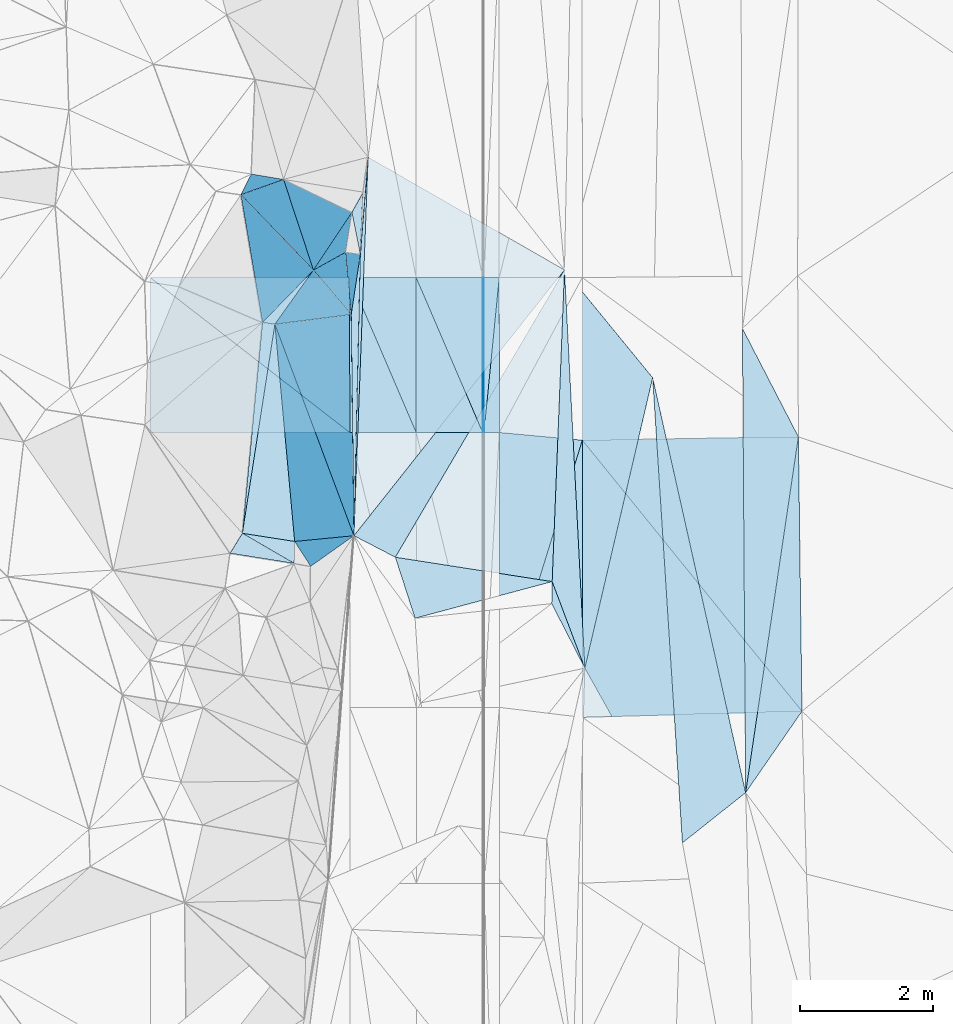
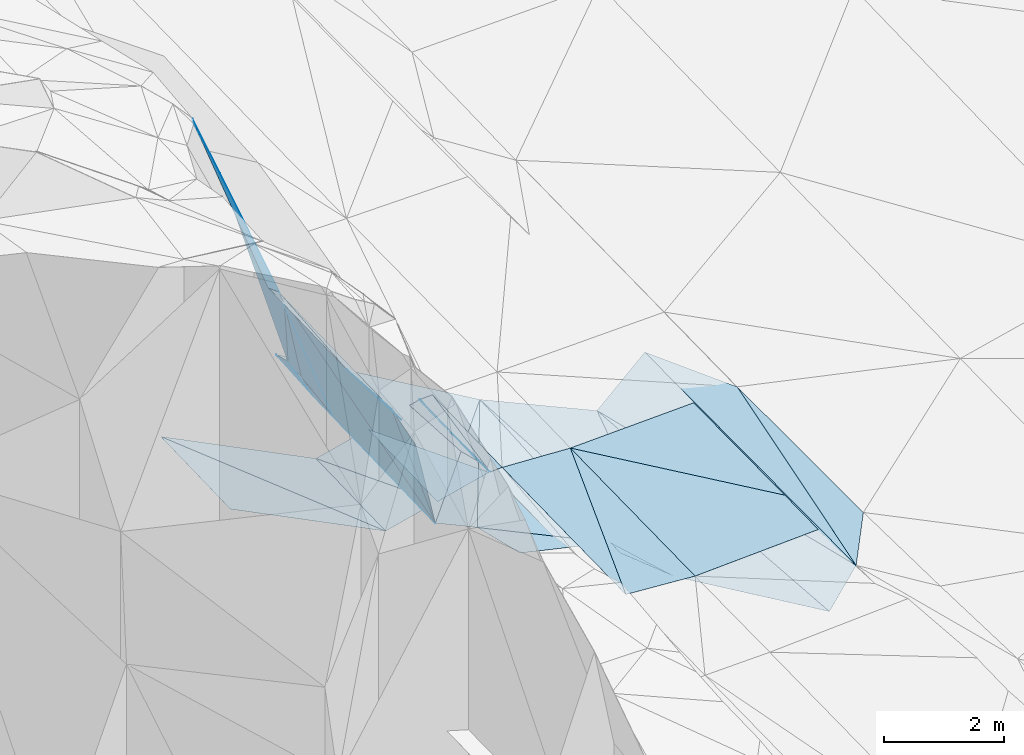
# One storey, part 138 of 275: 46 plates.
"""IFC2X3 building model written with IfcOpenShell, lengths in millimetres."""

from ifc_helpers import new_model, si_unit, frame, origin_with_axes, place, context, subcontext, project, spatial, polyline, outline, extrude, material, type_object, element, save


model = new_model("IFC2X3")

# Units and contexts
model_context = context("Model", 3, precision=1e-05, world=origin_with_axes())
body_context = subcontext(model_context, "Body", "Model", "MODEL_VIEW")
ifc_project = project(units=[si_unit("LENGTHUNIT", "METRE", prefix="MILLI"), si_unit("AREAUNIT", "SQUARE_METRE"), si_unit("VOLUMEUNIT", "CUBIC_METRE"), si_unit("MASSUNIT", "GRAM", prefix="KILO"), si_unit("TIMEUNIT", "SECOND"), si_unit("PLANEANGLEUNIT", "RADIAN"), si_unit("SOLIDANGLEUNIT", "STERADIAN"), si_unit("THERMODYNAMICTEMPERATUREUNIT", "DEGREE_CELSIUS"), si_unit("LUMINOUSINTENSITYUNIT", "LUMEN")], contexts=[model_context])

# Site, building, storey
site_placement = place(None, origin_with_axes())
site = spatial("IfcSite", under=ifc_project, at=site_placement, CompositionType="ELEMENT")
building_placement = place(site_placement, origin_with_axes())
building = spatial("IfcBuilding", under=site, at=building_placement, Name="Undefined", CompositionType="ELEMENT")
storey_placement = place(building_placement, origin_with_axes())
storey = spatial("IfcBuildingStorey", under=building, at=storey_placement, Name="Undefined", CompositionType="ELEMENT", Elevation=0.0)

# Plates
ifc_material = material()
plate_type_1 = type_object("IfcPlateType", PredefinedType="NOTDEFINED")
plate_1_placement = place(storey_placement, frame((-95658.5465812764, 121537.583320216, 43417.3598441609), z_axis=(0.0499079770275028, 0.0298258743354979, -0.99830837472654), x_axis=(0.998752208044659, 0.000305680057574922, 0.0499392980088953)))
element("IfcPlate", 1, at=plate_1_placement, inside=storey, type_object=plate_type_1, material=ifc_material, Name="00_PR", context=body_context, shape_type="SweptSolid", body=[
    extrude(outline(polyline([(0.0, 0.0), (20.0243110656738, 1.45519152283669e-11), (16.5821189880371, 2332.28637695313), (0.0, 0.0)])), frame((-8.85201319254618e-08, 2.18876761149539e-07, -0.5000001331573), z_axis=(0.0, 0.0, 1.0), x_axis=(1.0, 0.0, 0.0)), (0.0, 0.0, 1.0), 1.0),
])
plate_2_placement = place(storey_placement, frame((-95637.7995334225, 119206.33975076, 43348.7478433141), z_axis=(0.0499051006072341, 0.0298258526339781, -0.99830851917032), x_axis=(-0.998752315521962, -0.000325847078123489, -0.0499370209684242)))
element("IfcPlate", 2, at=plate_2_placement, inside=storey, type_object=plate_type_1, material=ifc_material, Name="00_PR", context=body_context, shape_type="SweptSolid", body=[
    extrude(outline(polyline([(0.0, 0.0), (20.0252170562744, 7.18500814400613e-11), (16.5352630615234, 2332.28662109375), (0.0, 0.0)])), frame((-8.85201319254618e-08, 2.18876761149539e-07, -0.5000001331573), z_axis=(0.0, 0.0, 1.0), x_axis=(1.0, 0.0, 0.0)), (0.0, 0.0, 1.0), 1.0),
])
plate_type_2 = type_object("IfcPlateType", PredefinedType="NOTDEFINED")
plate_3_placement = place(storey_placement, frame((-94612.0445225664, 116961.970986171, 42909.5017592129), z_axis=(-0.0781742209155372, 0.0316970105874069, -0.996435693210591), x_axis=(0.352555243814352, -0.934030698293048, -0.0573712010089046)))
element("IfcPlate", 3, at=plate_3_placement, inside=storey, type_object=plate_type_2, material=ifc_material, Name="00", context=body_context, shape_type="SweptSolid", body=[
    extrude(outline(polyline([(0.0, 0.0), (1394.42785644531, -1.54250301420689e-09), (307.351867675781, 123.42945098877), (0.0, 0.0)])), frame((-8.85201319254618e-08, 2.18876761149539e-07, -0.5000001331573), z_axis=(0.0, 0.0, 1.0), x_axis=(1.0, 0.0, 0.0)), (0.0, 0.0, 1.0), 1.0),
])
plate_type_3 = type_object("IfcPlateType", PredefinedType="NOTDEFINED")
plate_4_placement = place(storey_placement, frame((-97381.6370553467, 123349.673672694, 43844.6174222747), z_axis=(-0.643773439996087, 0.0126041830211003, -0.765112339807675), x_axis=(-0.0374891696705451, -0.999183190085038, 0.0150835940312584)))
element("IfcPlate", 4, at=plate_4_placement, inside=storey, type_object=plate_type_3, material=ifc_material, Name="00", context=body_context, shape_type="SweptSolid", body=[
    extrude(outline(polyline([(0.0, 0.0), (5701.55859375, 9.56060830503702e-09), (1469.06457519531, 82.0872650146484), (0.0, 0.0)])), frame((-8.85201319254618e-08, 2.18876761149539e-07, -0.5000001331573), z_axis=(0.0, 0.0, 1.0), x_axis=(1.0, 0.0, 0.0)), (0.0, 0.0, 1.0), 1.0),
])
plate_type_4 = type_object("IfcPlateType", PredefinedType="NOTDEFINED")
plate_5_placement = place(storey_placement, frame((-100658.795151709, 121535.978794509, 44417.4119449137), z_axis=(-0.447062744340366, 0.0265550220239005, -0.894108345463888), x_axis=(0.894427130836624, 0.000286740053144665, -0.447213623901941)))
element("IfcPlate", 5, at=plate_5_placement, inside=storey, type_object=plate_type_4, material=ifc_material, Name="00_PR", context=body_context, shape_type="SweptSolid", body=[
    extrude(outline(polyline([(0.0, 0.0), (3354.10180664063, 1.95868778973818e-08), (3385.2333984375, 2332.0810546875), (0.0, 0.0)])), frame((-8.85201319254618e-08, 2.18876761149539e-07, -0.5000001331573), z_axis=(0.0, 0.0, 1.0), x_axis=(1.0, 0.0, 0.0)), (0.0, 0.0, 1.0), 1.0),
])
plate_6_placement = place(storey_placement, frame((-97658.0478131458, 119205.690859334, 42847.7999446499), z_axis=(-0.447062744340366, 0.0265550220239005, -0.894108345463888), x_axis=(-0.894427130836978, -0.000286740047867567, 0.447213623901237)))
element("IfcPlate", 6, at=plate_6_placement, inside=storey, type_object=plate_type_4, material=ifc_material, Name="00_PR", context=body_context, shape_type="SweptSolid", body=[
    extrude(outline(polyline([(0.0, 0.0), (3354.1025390625, 9.64791979640722e-09), (3385.23315429688, 2332.08154296875), (0.0, 0.0)])), frame((-8.85201319254618e-08, 2.18876761149539e-07, -0.5000001331573), z_axis=(0.0, 0.0, 1.0), x_axis=(1.0, 0.0, 0.0)), (0.0, 0.0, 1.0), 1.0),
])
plate_type_5 = type_object("IfcPlateType", PredefinedType="NOTDEFINED")
plate_7_placement = place(storey_placement, frame((-96657.7035409751, 119206.011805772, 43097.7621312227), z_axis=(0.242424745946868, 0.0290344301742493, -0.969735656979289), x_axis=(-0.970142426598338, -0.000310161090762803, -0.2425357209031)))
element("IfcPlate", 7, at=plate_7_placement, inside=storey, type_object=plate_type_5, material=ifc_material, Name="00_PR", context=body_context, shape_type="SweptSolid", body=[
    extrude(outline(polyline([(0.0, 0.0), (1030.77600097656, -5.77711034566164e-09), (1013.89495849609, 2332.22778320313), (0.0, 0.0)])), frame((-8.85201319254618e-08, 2.18876761149539e-07, -0.5000001331573), z_axis=(0.0, 0.0, 1.0), x_axis=(1.0, 0.0, 0.0)), (0.0, 0.0, 1.0), 1.0),
])
for number, where, z_axis, x_axis, name in (
    (8, (-95657.7035061591, 119206.332830265, 43347.7621305522), (0.242424745946868, 0.0290344301742493, -0.969735656979289), (-0.970142403271045, -0.000311047105442569, -0.242535813077531), "00_PR"),
    (9, (-97658.4508101215, 121536.941789986, 42917.3741297692), (0.242424745946868, 0.0290344301742493, -0.969735656979289), (0.970142455388523, 0.000311440077304942, 0.242535604103411), "00_PR"),
):
    element("IfcPlate", number, at=place(storey_placement, frame(where, z_axis=z_axis, x_axis=x_axis)), inside=storey, type_object=plate_type_5, material=ifc_material, Name=name, context=body_context, shape_type="SweptSolid", body=[
        extrude(outline(polyline([(0.0, 0.0), (1030.77648925781, -5.90807758271694e-09), (1013.89196777344, 2332.22900390625), (0.0, 0.0)])), frame((-8.85201319254618e-08, 2.18876761149539e-07, -0.5000001331573), z_axis=(0.0, 0.0, 1.0), x_axis=(1.0, 0.0, 0.0)), (0.0, 0.0, 1.0), 1.0),
    ])
plate_8_placement = place(storey_placement, frame((-95657.7035061591, 119206.332830265, 43347.7621305522), z_axis=(0.242424745946868, 0.0290344301742493, -0.969735656979289), x_axis=(-0.393517391905308, 0.916576564577753, -0.0709328100027581)))
element("IfcPlate", 10, at=plate_8_placement, inside=storey, type_object=plate_type_5, material=ifc_material, Name="00_PR", context=body_context, shape_type="SweptSolid", body=[
    extrude(outline(polyline([(0.0, 0.0), (2543.08276367188, 8.98216967470944e-09), (2132.12524414063, 945.312133789063), (0.0, 0.0)])), frame((-8.85201319254618e-08, 2.18876761149539e-07, -0.5000001331573), z_axis=(0.0, 0.0, 1.0), x_axis=(1.0, 0.0, 0.0)), (0.0, 0.0, 1.0), 1.0),
])
plate_type_6 = type_object("IfcPlateType", PredefinedType="NOTDEFINED")
plate_9_placement = place(storey_placement, frame((-95637.7995334225, 119206.33975076, 43348.7478433141), z_axis=(0.0499051006072341, 0.0298258526339781, -0.99830851917032), x_axis=(0.0978051129157227, 0.994603784735312, 0.034604497940805)))
element("IfcPlate", 11, at=plate_9_placement, inside=storey, type_object=plate_type_6, material=ifc_material, Name="00_PR", context=body_context, shape_type="SweptSolid", body=[
    extrude(outline(polyline([(0.0, 0.0), (2343.97265625, 6.28642737865448e-09), (22.9658794403076, 229.139053344727), (0.0, 0.0)])), frame((-8.85201319254618e-08, 2.18876761149539e-07, -0.5000001331573), z_axis=(0.0, 0.0, 1.0), x_axis=(1.0, 0.0, 0.0)), (0.0, 0.0, 1.0), 1.0),
])
plate_10_placement = place(storey_placement, frame((-95408.5470062799, 121537.66393312, 43429.8598437611), z_axis=(0.0499051006072341, 0.0298258526339781, -0.99830851917032), x_axis=(-0.0978051129160349, -0.994603784735217, -0.0346044979426536)))
element("IfcPlate", 12, at=plate_10_placement, inside=storey, type_object=plate_type_6, material=ifc_material, Name="00_PR", context=body_context, shape_type="SweptSolid", body=[
    extrude(outline(polyline([(0.0, 0.0), (2343.97265625, 6.28642737865448e-09), (22.9672431945801, 229.139434814453), (0.0, 0.0)])), frame((-8.85201319254618e-08, 2.18876761149539e-07, -0.5000001331573), z_axis=(0.0, 0.0, 1.0), x_axis=(1.0, 0.0, 0.0)), (0.0, 0.0, 1.0), 1.0),
])
plate_type_7 = type_object("IfcPlateType", PredefinedType="NOTDEFINED")
plate_11_placement = place(storey_placement, frame((-98971.6472052774, 120862.3255212, 47269.5910511023), z_axis=(-0.574333387850839, -0.0354169738250356, -0.817854997884621), x_axis=(0.815137676046402, -0.116815268749952, -0.567366514764969)))
element("IfcPlate", 13, at=plate_11_placement, inside=storey, type_object=plate_type_7, material=ifc_material, Name="00", context=body_context, shape_type="SweptSolid", body=[
    extrude(outline(polyline([(0.0, 0.0), (229.128784179688, 9.31322574615479e-10), (-74.6305160522461, 3206.0771484375), (0.0, 0.0)])), frame((-8.85201319254618e-08, 2.18876761149539e-07, -0.5000001331573), z_axis=(0.0, 0.0, 1.0), x_axis=(1.0, 0.0, 0.0)), (0.0, 0.0, 1.0), 1.0),
])
plate_type_8 = type_object("IfcPlateType", PredefinedType="NOTDEFINED")
plate_12_placement = place(storey_placement, frame((-95406.4852202298, 115069.545098383, 43272.7192748336), z_axis=(0.0262317216422798, 0.0205335217921216, -0.99944498160854), x_axis=(0.29648818201697, 0.95464353723715, 0.0273947939509348)))
element("IfcPlate", 14, at=plate_12_placement, inside=storey, type_object=plate_type_8, material=ifc_material, Name="00_PR", context=body_context, shape_type="SweptSolid", body=[
    extrude(outline(polyline([(0.0, 0.0), (4211.67626953125, -1.08848325908184e-08), (227.990646362305, 1238.59069824219), (0.0, 0.0)])), frame((-8.85201319254618e-08, 2.18876761149539e-07, -0.5000001331573), z_axis=(0.0, 0.0, 1.0), x_axis=(1.0, 0.0, 0.0)), (0.0, 0.0, 1.0), 1.0),
])
plate_type_9 = type_object("IfcPlateType", PredefinedType="NOTDEFINED")
plate_13_placement = place(storey_placement, frame((-94157.7739965235, 119090.194874973, 43388.0972559141), z_axis=(0.0242345096749685, 0.0211548804940838, -0.999482445854901), x_axis=(-0.296488182022783, -0.954643537235384, -0.0273947939495716)))
element("IfcPlate", 15, at=plate_13_placement, inside=storey, type_object=plate_type_9, material=ifc_material, Name="00_PR", context=body_context, shape_type="SweptSolid", body=[
    extrude(outline(polyline([(0.0, 0.0), (4211.67626953125, -1.08848325908184e-08), (260.441955566406, 1228.43310546875), (0.0, 0.0)])), frame((-8.85201319254618e-08, 2.18876761149539e-07, -0.5000001331573), z_axis=(0.0, 0.0, 1.0), x_axis=(1.0, 0.0, 0.0)), (0.0, 0.0, 1.0), 1.0),
])
plate_type_10 = type_object("IfcPlateType", PredefinedType="NOTDEFINED")
plate_14_placement = place(storey_placement, frame((-90906.7705037649, 119141.242669645, 43469.5002467755), z_axis=(0.0247176876204582, 0.0196883582750342, -0.99950057752216), x_axis=(0.0131786120952445, -0.999725586362393, -0.0193668829606562)))
element("IfcPlate", 16, at=plate_14_placement, inside=storey, type_object=plate_type_10, material=ifc_material, Name="00_PR", context=body_context, shape_type="SweptSolid", body=[
    extrude(outline(polyline([(0.0, 0.0), (4130.7626953125, -2.75467755272985e-08), (9.7673282623291, 3252.408203125), (0.0, 0.0)])), frame((-8.85201319254618e-08, 2.18876761149539e-07, -0.5000001331573), z_axis=(0.0, 0.0, 1.0), x_axis=(1.0, 0.0, 0.0)), (0.0, 0.0, 1.0), 1.0),
])
plate_type_11 = type_object("IfcPlateType", PredefinedType="NOTDEFINED")
plate_15_placement = place(storey_placement, frame((-94156.4359207208, 114919.281160099, 43302.4412685696), z_axis=(0.0257606395534528, 0.0205336223390942, -0.999457232603493), x_axis=(-0.0003205620928807, 0.999789141202896, 0.0205321789569755)))
element("IfcPlate", 17, at=plate_15_placement, inside=storey, type_object=plate_type_11, material=ifc_material, Name="00_PR", context=body_context, shape_type="SweptSolid", body=[
    extrude(outline(polyline([(0.0, 0.0), (4171.79296875, -2.35158950090408e-08), (93.0415725708008, 3305.23046875), (0.0, 0.0)])), frame((-8.85201319254618e-08, 2.18876761149539e-07, -0.5000001331573), z_axis=(0.0, 0.0, 1.0), x_axis=(1.0, 0.0, 0.0)), (0.0, 0.0, 1.0), 1.0),
])
plate_type_12 = type_object("IfcPlateType", PredefinedType="NOTDEFINED")
plate_16_placement = place(storey_placement, frame((-98971.790943246, 120862.504499521, 47269.8042395773), z_axis=(-0.861808850019146, 0.322537664021406, -0.391477919321502), x_axis=(-0.107846525386788, 0.63762915718282, 0.762756963175246)))
element("IfcPlate", 18, at=plate_16_placement, inside=storey, type_object=plate_type_12, material=ifc_material, Name="00", context=body_context, shape_type="SweptSolid", body=[
    extrude(outline(polyline([(0.0, 0.0), (3015.37719726563, -4.67116478830576e-09), (-373.916717529297, 1466.38549804688), (0.0, 0.0)])), frame((-8.85201319254618e-08, 2.18876761149539e-07, -0.5000001331573), z_axis=(0.0, 0.0, 1.0), x_axis=(1.0, 0.0, 0.0)), (0.0, 0.0, 1.0), 1.0),
])
plate_type_13 = type_object("IfcPlateType", PredefinedType="NOTDEFINED")
plate_17_placement = place(storey_placement, frame((-91700.157788298, 113786.124309461, 43348.5055086008), z_axis=(0.147711294322029, 0.0115631826891528, -0.988962924651783), x_axis=(-0.777333468535915, -0.616884155305373, -0.123315115160715)))
element("IfcPlate", 19, at=plate_17_placement, inside=storey, type_object=plate_type_13, material=ifc_material, Name="00", context=body_context, shape_type="SweptSolid", body=[
    extrude(outline(polyline([(0.0, 0.0), (1224.50524902344, -2.03726813197136e-09), (-2747.5146484375, 5781.0390625), (0.0, 0.0)])), frame((-8.85201319254618e-08, 2.18876761149539e-07, -0.5000001331573), z_axis=(0.0, 0.0, 1.0), x_axis=(1.0, 0.0, 0.0)), (0.0, 0.0, 1.0), 1.0),
])
plate_type_14 = type_object("IfcPlateType", PredefinedType="NOTDEFINED")
plate_18_placement = place(storey_placement, frame((-91700.2216783129, 113786.128349822, 43348.5001840481), z_axis=(0.0199676774914359, 0.019627822867542, -0.999607943358334), x_axis=(0.146529848346511, 0.988953829190207, 0.0223456320916487)))
element("IfcPlate", 20, at=plate_18_placement, inside=storey, type_object=plate_type_14, material=ifc_material, Name="00", context=body_context, shape_type="SweptSolid", body=[
    extrude(outline(polyline([(0.0, 0.0), (5414.9287109375, -9.63336788117886e-09), (1337.10498046875, 659.208801269531), (0.0, 0.0)])), frame((-8.85201319254618e-08, 2.18876761149539e-07, -0.5000001331573), z_axis=(0.0, 0.0, 1.0), x_axis=(1.0, 0.0, 0.0)), (0.0, 0.0, 1.0), 1.0),
])
plate_type_15 = type_object("IfcPlateType", PredefinedType="NOTDEFINED")
plate_19_placement = place(storey_placement, frame((-96675.4428162585, 116410.586847722, 43749.5352270313), z_axis=(-0.365775590191558, -0.0473228513057416, -0.929499201379061), x_axis=(-0.306603443637589, 0.949084864792472, 0.0723342779837206)))
element("IfcPlate", 21, at=plate_19_placement, inside=storey, type_object=plate_type_15, material=ifc_material, Name="00", context=body_context, shape_type="SweptSolid", body=[
    extrude(outline(polyline([(0.0, 0.0), (967.729309082031, -8.0763129517436e-10), (-170.088882446289, 2288.595703125), (0.0, 0.0)])), frame((-8.85201319254618e-08, 2.18876761149539e-07, -0.5000001331573), z_axis=(0.0, 0.0, 1.0), x_axis=(1.0, 0.0, 0.0)), (0.0, 0.0, 1.0), 1.0),
])
plate_type_16 = type_object("IfcPlateType", PredefinedType="NOTDEFINED")
plate_20_placement = place(storey_placement, frame((-98204.6886380765, 121649.884811081, 46229.812256291), z_axis=(-0.894059232117318, 0.2443355448353, -0.375444045093046), x_axis=(-0.295787267149593, 0.307419460808714, 0.904435275577117)))
element("IfcPlate", 22, at=plate_20_placement, inside=storey, type_object=plate_type_16, material=ifc_material, Name="00", context=body_context, shape_type="SweptSolid", body=[
    extrude(outline(polyline([(0.0, 0.0), (3692.912109375, -2.57568899542093e-09), (2325.3193359375, 706.392211914063), (0.0, 0.0)])), frame((-8.85201319254618e-08, 2.18876761149539e-07, -0.5000001331573), z_axis=(0.0, 0.0, 1.0), x_axis=(1.0, 0.0, 0.0)), (0.0, 0.0, 1.0), 1.0),
])
plate_type_17 = type_object("IfcPlateType", PredefinedType="NOTDEFINED")
plate_21_placement = place(storey_placement, frame((-97499.5464607995, 121884.96316344, 43919.7260674068), z_axis=(-0.836410564111561, 0.0175355695345447, -0.547822847318072), x_axis=(-0.0226617156947316, -0.99973981349589, 0.00259845203412957)))
element("IfcPlate", 23, at=plate_21_placement, inside=storey, type_object=plate_type_17, material=ifc_material, Name="00", context=body_context, shape_type="SweptSolid", body=[
    extrude(outline(polyline([(0.0, 0.0), (4233.2900390625, 3.60887497663498e-09), (905.709228515625, 212.345932006836), (0.0, 0.0)])), frame((-8.85201319254618e-08, 2.18876761149539e-07, -0.5000001331573), z_axis=(0.0, 0.0, 1.0), x_axis=(1.0, 0.0, 0.0)), (0.0, 0.0, 1.0), 1.0),
])
plate_type_18 = type_object("IfcPlateType", PredefinedType="NOTDEFINED")
plate_22_placement = place(storey_placement, frame((-98494.5510908, 117235.615550739, 46609.6897157309), z_axis=(-0.783417619860374, 0.0347049513477214, -0.620525905377252), x_axis=(-0.575914645240404, 0.334777643873149, 0.745819180874535)))
element("IfcPlate", 24, at=plate_22_placement, inside=storey, type_object=plate_type_18, material=ifc_material, Name="00", context=body_context, shape_type="SweptSolid", body=[
    extrude(outline(polyline([(0.0, 0.0), (1354.21569824219, -3.87080945074558e-09), (114.38355255127, 310.831787109375), (0.0, 0.0)])), frame((-8.85201319254618e-08, 2.18876761149539e-07, -0.5000001331573), z_axis=(0.0, 0.0, 1.0), x_axis=(1.0, 0.0, 0.0)), (0.0, 0.0, 1.0), 1.0),
])
plate_type_19 = type_object("IfcPlateType", PredefinedType="NOTDEFINED")
plate_23_placement = place(storey_placement, frame((-99458.8382962575, 117388.762550074, 47879.6989706981), z_axis=(-0.797867471796841, -0.0313916628241235, -0.602015000605179), x_axis=(0.421088104905847, 0.685602278091095, -0.593830214946245)))
element("IfcPlate", 25, at=plate_23_placement, inside=storey, type_object=plate_type_19, material=ifc_material, Name="00", context=body_context, shape_type="SweptSolid", body=[
    extrude(outline(polyline([(0.0, 0.0), (437.835571289063, 1.19325704872608e-09), (1055.19067382813, 1205.31018066406), (0.0, 0.0)])), frame((-8.85201319254618e-08, 2.18876761149539e-07, -0.5000001331573), z_axis=(0.0, 0.0, 1.0), x_axis=(1.0, 0.0, 0.0)), (0.0, 0.0, 1.0), 1.0),
])
plate_type_20 = type_object("IfcPlateType", PredefinedType="NOTDEFINED")
plate_24_placement = place(storey_placement, frame((-98487.8880952177, 117566.529177755, 46619.8418969273), z_axis=(-0.94126941283574, -0.118544202764886, -0.316163192751305), x_axis=(0.314818307195399, 0.0304028510503706, -0.948664904011228)))
element("IfcPlate", 26, at=plate_24_placement, inside=storey, type_object=plate_type_20, material=ifc_material, Name="00", context=body_context, shape_type="SweptSolid", body=[
    extrude(outline(polyline([(0.0, 0.0), (2834.509765625, 9.02218744158745e-09), (615.016418457031, 395.796478271484), (0.0, 0.0)])), frame((-8.85201319254618e-08, 2.18876761149539e-07, -0.5000001331573), z_axis=(0.0, 0.0, 1.0), x_axis=(1.0, 0.0, 0.0)), (0.0, 0.0, 1.0), 1.0),
])
plate_type_21 = type_object("IfcPlateType", PredefinedType="NOTDEFINED")
plate_25_placement = place(storey_placement, frame((-98204.6931630356, 121649.901300235, 46229.8360653396), z_axis=(-0.903115540307248, 0.277329966888523, -0.327826799272357), x_axis=(0.246737566347541, -0.289669656055448, -0.924776764259144)))
element("IfcPlate", 27, at=plate_25_placement, inside=storey, type_object=plate_type_21, material=ifc_material, Name="00", context=body_context, shape_type="SweptSolid", body=[
    extrude(outline(polyline([(0.0, 0.0), (2303.25854492188, 1.57160684466362e-09), (-748.8955078125, 1125.59118652344), (0.0, 0.0)])), frame((-8.85201319254618e-08, 2.18876761149539e-07, -0.5000001331573), z_axis=(0.0, 0.0, 1.0), x_axis=(1.0, 0.0, 0.0)), (0.0, 0.0, 1.0), 1.0),
])
plate_type_22 = type_object("IfcPlateType", PredefinedType="NOTDEFINED")
plate_26_placement = place(storey_placement, frame((-94426.805484111, 121652.402118814, 42920.5049427691), z_axis=(-0.140283667766058, 0.00786306384697114, -0.990080130486942), x_axis=(0.0510452415499666, -0.998581224819285, -0.015163137983984)))
element("IfcPlate", 28, at=plate_26_placement, inside=storey, type_object=plate_type_22, material=ifc_material, Name="00", context=body_context, shape_type="SweptSolid", body=[
    extrude(outline(polyline([(0.0, 0.0), (6001.39599609375, 2.80269887298346e-08), (4674.498046875, 428.6845703125), (0.0, 0.0)])), frame((-8.85201319254618e-08, 2.18876761149539e-07, -0.5000001331573), z_axis=(0.0, 0.0, 1.0), x_axis=(1.0, 0.0, 0.0)), (0.0, 0.0, 1.0), 1.0),
])
plate_type_23 = type_object("IfcPlateType", PredefinedType="NOTDEFINED")
plate_27_placement = place(storey_placement, frame((-99297.0009791843, 122785.178936471, 49569.8176377472), z_axis=(-0.885969044447969, 0.286473814897998, -0.364680141573051), x_axis=(0.420890908724263, 0.826888803979803, -0.372968830877481)))
element("IfcPlate", 29, at=plate_27_placement, inside=storey, type_object=plate_type_23, material=ifc_material, Name="00", context=body_context, shape_type="SweptSolid", body=[
    extrude(outline(polyline([(0.0, 0.0), (375.366485595703, 1.90630089491606e-09), (974.514282226563, 1191.47888183594), (0.0, 0.0)])), frame((-8.85201319254618e-08, 2.18876761149539e-07, -0.5000001331573), z_axis=(0.0, 0.0, 1.0), x_axis=(1.0, 0.0, 0.0)), (0.0, 0.0, 1.0), 1.0),
])
plate_type_24 = type_object("IfcPlateType", PredefinedType="NOTDEFINED")
plate_28_placement = place(storey_placement, frame((-97499.6196387175, 121884.989552345, 43919.9145034988), z_axis=(-0.982769031567734, 0.0702949031927128, -0.170949282468649), x_axis=(0.046921451665912, 0.989443086174038, 0.137115851001839)))
element("IfcPlate", 30, at=plate_28_placement, inside=storey, type_object=plate_type_24, material=ifc_material, Name="00", context=body_context, shape_type="SweptSolid", body=[
    extrude(outline(polyline([(0.0, 0.0), (948.103393554688, 4.03088051825762e-09), (1444.49438476563, 279.865966796875), (0.0, 0.0)])), frame((-8.85201319254618e-08, 2.18876761149539e-07, -0.5000001331573), z_axis=(0.0, 0.0, 1.0), x_axis=(1.0, 0.0, 0.0)), (0.0, 0.0, 1.0), 1.0),
])
plate_type_25 = type_object("IfcPlateType", PredefinedType="NOTDEFINED")
plate_29_placement = place(storey_placement, frame((-97636.4247399197, 120982.572368901, 44099.8728924768), z_axis=(-0.967080638859913, -0.0122967499738444, -0.254172830732128), x_axis=(-0.246737566355202, 0.28966965606316, 0.924776764254684)))
element("IfcPlate", 31, at=plate_29_placement, inside=storey, type_object=plate_type_25, material=ifc_material, Name="00", context=body_context, shape_type="SweptSolid", body=[
    extrude(outline(polyline([(0.0, 0.0), (2303.25854492188, 1.57160684466362e-09), (550.958557128906, 810.521240234375), (0.0, 0.0)])), frame((-8.85201319254618e-08, 2.18876761149539e-07, -0.5000001331573), z_axis=(0.0, 0.0, 1.0), x_axis=(1.0, 0.0, 0.0)), (0.0, 0.0, 1.0), 1.0),
])
plate_type_26 = type_object("IfcPlateType", PredefinedType="NOTDEFINED")
plate_30_placement = place(storey_placement, frame((-91700.2211172175, 113786.128271702, 43348.5001878943), z_axis=(0.0210686695352378, 0.0194642543992461, -0.999588542333643), x_axis=(-0.00698845453885841, 0.999788910695705, 0.0193208579792212)))
element("IfcPlate", 32, at=plate_30_placement, inside=storey, type_object=plate_type_26, material=ifc_material, Name="00", context=body_context, shape_type="SweptSolid", body=[
    extrude(outline(polyline([(0.0, 0.0), (6987.267578125, -4.38594724982977e-08), (5350.77685546875, 831.047058105469), (0.0, 0.0)])), frame((-8.85201319254618e-08, 2.18876761149539e-07, -0.5000001331573), z_axis=(0.0, 0.0, 1.0), x_axis=(1.0, 0.0, 0.0)), (0.0, 0.0, 1.0), 1.0),
])
plate_type_27 = type_object("IfcPlateType", PredefinedType="NOTDEFINED")
plate_31_placement = place(storey_placement, frame((-97626.3025885863, 122517.818310968, 44259.8816808133), z_axis=(-0.965744550667328, 0.106585407436626, -0.236594619080676), x_axis=(-0.154402787735836, -0.968814272079973, 0.193800633006073)))
element("IfcPlate", 33, at=plate_31_placement, inside=storey, type_object=plate_type_27, material=ifc_material, Name="00", context=body_context, shape_type="SweptSolid", body=[
    extrude(outline(polyline([(0.0, 0.0), (619.192993164063, 4.08908817917109e-09), (1312.0302734375, 1802.07556152344), (0.0, 0.0)])), frame((-8.85201319254618e-08, 2.18876761149539e-07, -0.5000001331573), z_axis=(0.0, 0.0, 1.0), x_axis=(1.0, 0.0, 0.0)), (0.0, 0.0, 1.0), 1.0),
])
plate_type_28 = type_object("IfcPlateType", PredefinedType="NOTDEFINED")
plate_32_placement = place(storey_placement, frame((-98204.7237512493, 121649.789754429, 46229.8703621513), z_axis=(-0.964290703801535, 0.0542366721289129, -0.259233142090899), x_axis=(-0.185234817306501, 0.561464080882856, 0.806502416819564)))
element("IfcPlate", 34, at=plate_32_placement, inside=storey, type_object=plate_type_28, material=ifc_material, Name="00", context=body_context, shape_type="SweptSolid", body=[
    extrude(outline(polyline([(0.0, 0.0), (2430.24682617188, -3.57977114617825e-09), (-1208.60144042969, 1873.01428222656), (0.0, 0.0)])), frame((-8.85201319254618e-08, 2.18876761149539e-07, -0.5000001331573), z_axis=(0.0, 0.0, 1.0), x_axis=(1.0, 0.0, 0.0)), (0.0, 0.0, 1.0), 1.0),
])
plate_type_29 = type_object("IfcPlateType", PredefinedType="NOTDEFINED")
plate_33_placement = place(storey_placement, frame((-98487.8094783951, 117566.602134279, 46619.6899216216), z_axis=(-0.78403460750556, 0.0273682787911048, -0.62011346667333), x_axis=(-0.615438427281133, 0.0957367318740247, 0.7823490400044)))
element("IfcPlate", 35, at=plate_33_placement, inside=storey, type_object=plate_type_29, material=ifc_material, Name="00", context=body_context, shape_type="SweptSolid", body=[
    extrude(outline(polyline([(0.0, 0.0), (1278.20190429688, 4.10364009439945e-09), (902.67431640625, 3198.46508789063), (0.0, 0.0)])), frame((-8.85201319254618e-08, 2.18876761149539e-07, -0.5000001331573), z_axis=(0.0, 0.0, 1.0), x_axis=(1.0, 0.0, 0.0)), (0.0, 0.0, 1.0), 1.0),
])
plate_type_30 = type_object("IfcPlateType", PredefinedType="NOTDEFINED")
plate_34_placement = place(storey_placement, frame((-97721.8738109129, 121917.906413175, 44379.7812663568), z_axis=(-0.897925391178671, 0.0488835785327108, -0.437424722239687), x_axis=(0.43420947328758, -0.0643170699121014, -0.898512909103283)))
element("IfcPlate", 36, at=plate_34_placement, inside=storey, type_object=plate_type_30, material=ifc_material, Name="00", context=body_context, shape_type="SweptSolid", body=[
    extrude(outline(polyline([(0.0, 0.0), (511.95703125, -1.87719706445932e-09), (348.857391357422, 915.859436035156), (0.0, 0.0)])), frame((-8.85201319254618e-08, 2.18876761149539e-07, -0.5000001331573), z_axis=(0.0, 0.0, 1.0), x_axis=(1.0, 0.0, 0.0)), (0.0, 0.0, 1.0), 1.0),
])
plate_type_31 = type_object("IfcPlateType", PredefinedType="NOTDEFINED")
plate_35_placement = place(storey_placement, frame((-97626.2417596893, 122517.821358163, 44259.7378587804), z_axis=(-0.844083938867757, 0.11267660573273, -0.524238768755273), x_axis=(0.419382271845533, 0.747938920109645, -0.514495754935741)))
element("IfcPlate", 37, at=plate_35_placement, inside=storey, type_object=plate_type_31, material=ifc_material, Name="00", context=body_context, shape_type="SweptSolid", body=[
    extrude(outline(polyline([(0.0, 0.0), (408.166625976563, -4.65661287307739e-10), (-245.242980957031, 686.990478515625), (0.0, 0.0)])), frame((-8.85201319254618e-08, 2.18876761149539e-07, -0.5000001331573), z_axis=(0.0, 0.0, 1.0), x_axis=(1.0, 0.0, 0.0)), (0.0, 0.0, 1.0), 1.0),
])
plate_type_32 = type_object("IfcPlateType", PredefinedType="NOTDEFINED")
plate_36_placement = place(storey_placement, frame((-94120.2693658509, 115659.530381566, 42829.5156141408), z_axis=(0.24652713649732, 0.0273120924176394, -0.96875095900763), x_axis=(-0.0510452415208624, 0.998581224804928, 0.0151631390274822)))
element("IfcPlate", 38, at=plate_36_placement, inside=storey, type_object=plate_type_32, material=ifc_material, Name="00", context=body_context, shape_type="SweptSolid", body=[
    extrude(outline(polyline([(0.0, 0.0), (6001.39599609375, 2.80269887298346e-08), (4318.49853515625, 1282.53039550781), (0.0, 0.0)])), frame((-8.85201319254618e-08, 2.18876761149539e-07, -0.5000001331573), z_axis=(0.0, 0.0, 1.0), x_axis=(1.0, 0.0, 0.0)), (0.0, 0.0, 1.0), 1.0),
])
plate_type_33 = type_object("IfcPlateType", PredefinedType="NOTDEFINED")
plate_37_placement = place(storey_placement, frame((-98204.5218185318, 121649.559221542, 46229.6392790165), z_axis=(-0.560422630595203, -0.40682861520177, -0.721399302030271), x_axis=(-0.429262895027501, -0.602225079232833, 0.673096071074268)))
element("IfcPlate", 39, at=plate_37_placement, inside=storey, type_object=plate_type_33, material=ifc_material, Name="00", context=body_context, shape_type="SweptSolid", body=[
    extrude(outline(polyline([(0.0, 0.0), (1351.96154785156, -1.22236087918282e-09), (1503.51904296875, 171.843841552734), (0.0, 0.0)])), frame((-8.85201319254618e-08, 2.18876761149539e-07, -0.5000001331573), z_axis=(0.0, 0.0, 1.0), x_axis=(1.0, 0.0, 0.0)), (0.0, 0.0, 1.0), 1.0),
])
plate_type_34 = type_object("IfcPlateType", PredefinedType="NOTDEFINED")
plate_38_placement = place(storey_placement, frame((-98785.0626077645, 120835.559511907, 47139.8420796466), z_axis=(-0.948144813806935, -0.0359579652862168, -0.315798094964945), x_axis=(0.254518040277133, -0.681012936746411, -0.686616302717549)))
element("IfcPlate", 40, at=plate_38_placement, inside=storey, type_object=plate_type_34, material=ifc_material, Name="00", context=body_context, shape_type="SweptSolid", body=[
    extrude(outline(polyline([(0.0, 0.0), (4673.6435546875, -1.00553734228015e-08), (2658.89965820313, 1993.80346679688), (0.0, 0.0)])), frame((-8.85201319254618e-08, 2.18876761149539e-07, -0.5000001331573), z_axis=(0.0, 0.0, 1.0), x_axis=(1.0, 0.0, 0.0)), (0.0, 0.0, 1.0), 1.0),
])
plate_type_35 = type_object("IfcPlateType", PredefinedType="NOTDEFINED")
plate_39_placement = place(storey_placement, frame((-97636.4089667437, 120982.581736787, 44099.8233912919), z_axis=(-0.935534974492576, 0.0064395827486796, -0.353175371841241), x_axis=(0.0122600583250673, -0.998639458145466, -0.0506845499614571)))
element("IfcPlate", 41, at=plate_39_placement, inside=storey, type_object=plate_type_35, material=ifc_material, Name="00", context=body_context, shape_type="SweptSolid", body=[
    extrude(outline(polyline([(0.0, 0.0), (3334.34936523438, -2.14058673009276e-08), (-21.3624877929688, 3253.02075195313), (0.0, 0.0)])), frame((-8.85201319254618e-08, 2.18876761149539e-07, -0.5000001331573), z_axis=(0.0, 0.0, 1.0), x_axis=(1.0, 0.0, 0.0)), (0.0, 0.0, 1.0), 1.0),
])
plate_type_36 = type_object("IfcPlateType", PredefinedType="NOTDEFINED")
plate_40_placement = place(storey_placement, frame((-96972.1478253857, 117329.075900454, 43819.5330953022), z_axis=(-0.357520703326431, 0.0163117424590377, -0.933762750248115), x_axis=(0.499376551720083, 0.848240298762087, -0.176384395988321)))
element("IfcPlate", 42, at=plate_40_placement, inside=storey, type_object=plate_type_36, material=ifc_material, Name="00", context=body_context, shape_type="SweptSolid", body=[
    extrude(outline(polyline([(0.0, 0.0), (5096.82275390625, -4.94765117764473e-10), (1027.62060546875, 2340.14868164063), (0.0, 0.0)])), frame((-8.85201319254618e-08, 2.18876761149539e-07, -0.5000001331573), z_axis=(0.0, 0.0, 1.0), x_axis=(1.0, 0.0, 0.0)), (0.0, 0.0, 1.0), 1.0),
])
plate_type_37 = type_object("IfcPlateType", PredefinedType="NOTDEFINED")
plate_41_placement = place(storey_placement, frame((-97595.1686153627, 117652.727193362, 43930.513012132), z_axis=(-0.213432429540773, -0.0768682448461339, -0.973929089284532), x_axis=(0.609119538351103, 0.768940404196754, -0.194175288831179)))
element("IfcPlate", 43, at=plate_41_placement, inside=storey, type_object=plate_type_37, material=ifc_material, Name="00", context=body_context, shape_type="SweptSolid", body=[
    extrude(outline(polyline([(0.0, 0.0), (5201.48583984375, 1.92085281014442e-09), (152.187088012695, 694.3955078125), (0.0, 0.0)])), frame((-8.85201319254618e-08, 2.18876761149539e-07, -0.5000001331573), z_axis=(0.0, 0.0, 1.0), x_axis=(1.0, 0.0, 0.0)), (0.0, 0.0, 1.0), 1.0),
])
plate_type_38 = type_object("IfcPlateType", PredefinedType="NOTDEFINED")
plate_42_placement = place(storey_placement, frame((-93099.5175031134, 120030.52559607, 43212.5088111672), z_axis=(0.185981397438036, 0.0202837306190442, -0.982343875676522), x_axis=(0.863346747740304, 0.473941798510805, 0.173238462214899)))
element("IfcPlate", 44, at=plate_42_placement, inside=storey, type_object=plate_type_38, material=ifc_material, Name="00", context=body_context, shape_type="SweptSolid", body=[
    extrude(outline(polyline([(0.0, 0.0), (1564.31774902344, -6.98491930961609e-09), (-1727.77111816406, 6163.12060546875), (0.0, 0.0)])), frame((-8.85201319254618e-08, 2.18876761149539e-07, -0.5000001331573), z_axis=(0.0, 0.0, 1.0), x_axis=(1.0, 0.0, 0.0)), (0.0, 0.0, 1.0), 1.0),
])
plate_type_39 = type_object("IfcPlateType", PredefinedType="NOTDEFINED")
plate_43_placement = place(storey_placement, frame((-97595.2120031835, 117652.764062383, 43930.5230340498), z_axis=(-0.300120068836519, -0.00313949625924188, -0.953896266815633), x_axis=(0.0374891694374157, 0.999183190094367, -0.0150835939926795)))
element("IfcPlate", 45, at=plate_43_placement, inside=storey, type_object=plate_type_39, material=ifc_material, Name="00", context=body_context, shape_type="SweptSolid", body=[
    extrude(outline(polyline([(0.0, 0.0), (5701.55859375, 9.56060830503702e-09), (4130.3779296875, 3161.55517578125), (0.0, 0.0)])), frame((-8.85201319254618e-08, 2.18876761149539e-07, -0.5000001331573), z_axis=(0.0, 0.0, 1.0), x_axis=(1.0, 0.0, 0.0)), (0.0, 0.0, 1.0), 1.0),
])
plate_type_40 = type_object("IfcPlateType", PredefinedType="NOTDEFINED")
plate_44_placement = place(storey_placement, frame((-92651.9424668621, 113030.750531775, 43197.5195244456), z_axis=(0.276126645622814, 0.0197133106466724, -0.96091907097343), x_axis=(-0.484040079451664, 0.866595710686981, -0.121313955105555)))
element("IfcPlate", 46, at=plate_44_placement, inside=storey, type_object=plate_type_40, material=ifc_material, Name="00", context=body_context, shape_type="SweptSolid", body=[
    extrude(outline(polyline([(0.0, 0.0), (3033.45141601563, -4.53292159363627e-09), (6280.77734375, 3122.369140625), (0.0, 0.0)])), frame((-8.85201319254618e-08, 2.18876761149539e-07, -0.5000001331573), z_axis=(0.0, 0.0, 1.0), x_axis=(1.0, 0.0, 0.0)), (0.0, 0.0, 1.0), 1.0),
])

save(model, "model.ifc")
